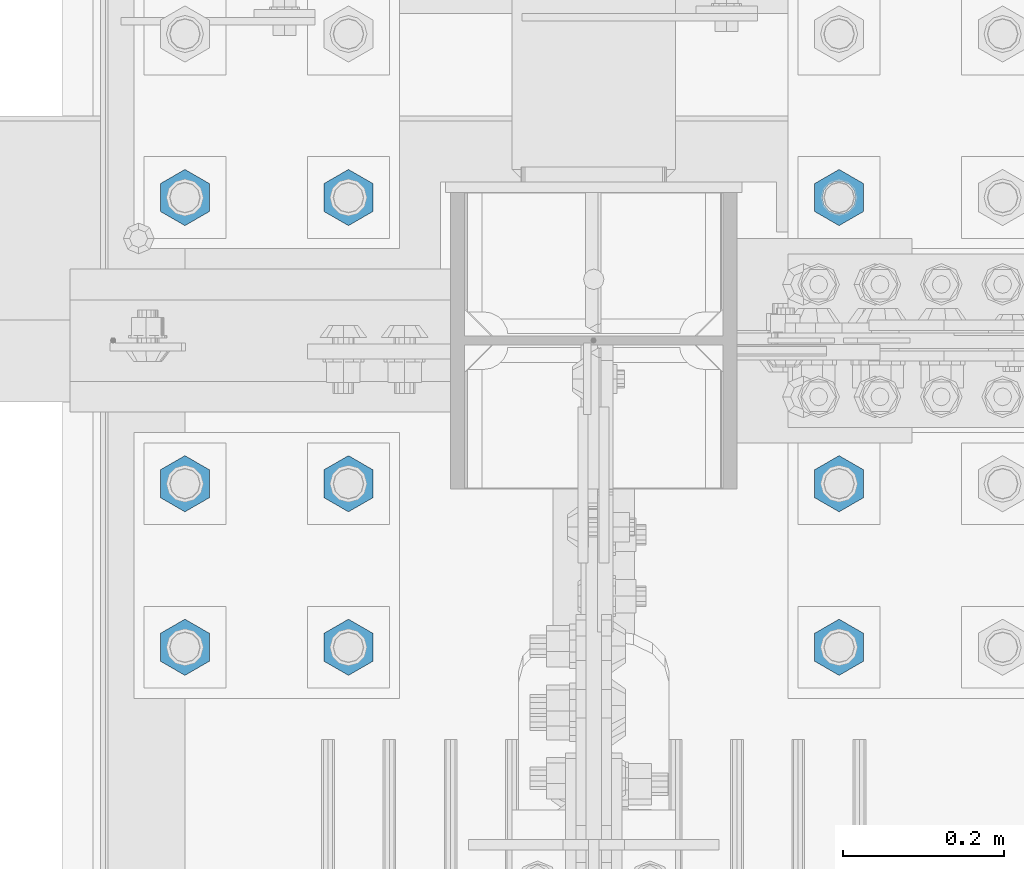
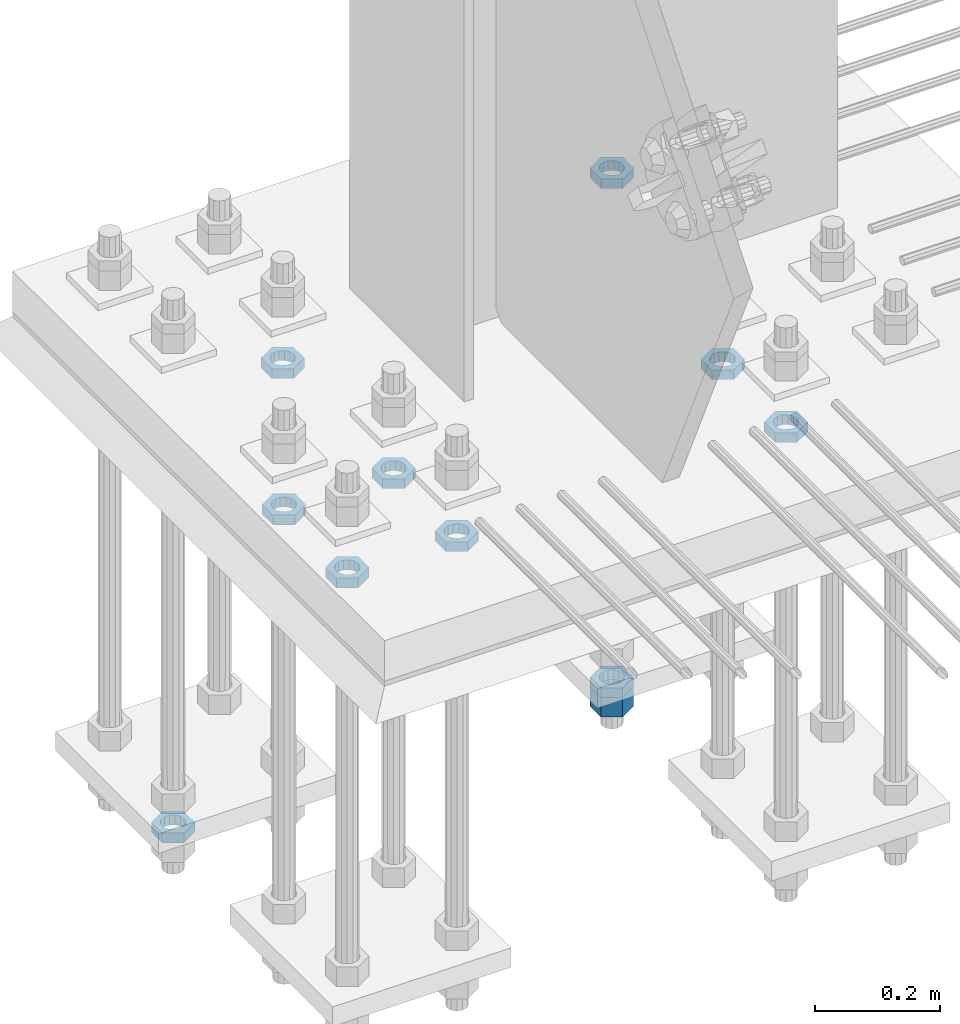
# One storey, part 2928 of 3843: 11 beams, 1 element without a shape of its own.
"""IFC2X3 building model written with IfcOpenShell, lengths in millimetres."""

from ifc_helpers import new_model, si_unit, frame, origin_with_axes, place, context, subcontext, project, spatial, faceted_brep, material, type_object, element, aggregate, save


model = new_model("IFC2X3")

# Units and contexts
model_context = context("Model", 3, precision=1e-05, world=origin_with_axes())
body_context = subcontext(model_context, "Body", "Model", "MODEL_VIEW")
ifc_project = project(units=[si_unit("LENGTHUNIT", "METRE", prefix="MILLI"), si_unit("AREAUNIT", "SQUARE_METRE"), si_unit("VOLUMEUNIT", "CUBIC_METRE"), si_unit("MASSUNIT", "GRAM", prefix="KILO"), si_unit("TIMEUNIT", "SECOND"), si_unit("PLANEANGLEUNIT", "RADIAN"), si_unit("SOLIDANGLEUNIT", "STERADIAN"), si_unit("THERMODYNAMICTEMPERATUREUNIT", "DEGREE_CELSIUS"), si_unit("LUMINOUSINTENSITYUNIT", "LUMEN")], contexts=[model_context])

# Site, building, storey
site_placement = place(None, origin_with_axes())
site = spatial("IfcSite", under=ifc_project, at=site_placement, CompositionType="ELEMENT")
building_placement = place(site_placement, origin_with_axes())
building = spatial("IfcBuilding", under=site, at=building_placement, Name="Undefined", CompositionType="ELEMENT")
storey_placement = place(building_placement, origin_with_axes())
storey = spatial("IfcBuildingStorey", under=building, at=storey_placement, Name="Undefined", CompositionType="ELEMENT", Elevation=0.0)

# Assembly, beams
assembly_placement = place(storey_placement, origin_with_axes())
assembly = element("IfcElementAssembly", 1, at=assembly_placement, inside=storey, Name="TEMPLATE", AssemblyPlace="NOTDEFINED", PredefinedType="RIGID_FRAME")
ifc_material = material(Name="STEEL/A572-50")
beam_type_1 = type_object("IfcBeamType", Name="1-1/2_HEAVY_HEX_NUT", PredefinedType="NOTDEFINED")
beam_1_placement = place(assembly_placement, frame((77317.6, 104736.9, 28746.4500015259), z_axis=(-1.0, 0.0, 0.0), x_axis=(0.0, 0.0, -1.0)))
beam_1 = element("IfcBeam", 2, at=beam_1_placement, type_object=beam_type_1, material=ifc_material, Name="NUT", ObjectType="1-1/2_HEAVY_HEX_NUT", context=body_context, shape_type="Brep", body=[
    faceted_brep([(0.0, -34.9199981689453, 0.0), (0.0, -17.4599990844727, -30.25), (38.0999999999985, -17.4599990844727, -30.25), (38.0999999999985, -34.9199981689453, 0.0), (0.0, 17.4599990844727, -30.25), (38.0999999999985, 17.4599990844727, -30.25), (0.0, 34.9199981689453, 0.0), (38.0999999999985, 34.9199981689453, 0.0), (0.0, 17.4599990844727, 30.25), (38.0999999999985, 17.4599990844727, 30.25), (0.0, -17.4599990844727, 30.25), (38.0999999999985, -17.4599990844727, 30.25), (0.0, 0.0, 20.6399993896484), (0.0, 8.9553601105581, 18.5959968835959), (38.0999999999985, 8.9553601105581, 18.5959968835959), (38.0999999999985, 0.0, 20.6399993896484), (0.0, 16.1370013209525, 12.8688291298167), (38.0999999999985, 16.1370013209525, 12.8688291298167), (0.0, 20.1225115123816, 4.59283194104501), (38.0999999999985, 20.1225115123816, 4.59283194104501), (0.0, 20.1225115123816, -4.59283194104501), (38.0999999999985, 20.1225115123816, -4.59283194104501), (0.0, 16.1370013209525, -12.8688291298167), (38.0999999999985, 16.1370013209525, -12.8688291298167), (0.0, 8.9553601105581, -18.5959968835959), (38.0999999999985, 8.9553601105581, -18.5959968835959), (0.0, 0.0, -20.6399993896484), (38.0999999999985, 0.0, -20.6399993896484), (0.0, -8.9553601105581, -18.5959968835959), (38.0999999999985, -8.9553601105581, -18.5959968835959), (0.0, -16.1370013209525, -12.8688291298167), (38.0999999999985, -16.1370013209525, -12.8688291298167), (0.0, -20.1225115123816, -4.59283194104501), (38.0999999999985, -20.1225115123816, -4.59283194104501), (0.0, -20.1225115123816, 4.59283194104501), (38.0999999999985, -20.1225115123816, 4.59283194104501), (0.0, -16.1370013209525, 12.8688291298167), (38.0999999999985, -16.1370013209525, 12.8688291298167), (0.0, -8.9553601105581, 18.5959968835959), (38.0999999999985, -8.9553601105581, 18.5959968835959)], [[[0, 1, 2, 3]], [[1, 4, 5, 2]], [[4, 6, 7, 5]], [[6, 8, 9, 7]], [[8, 10, 11, 9]], [[10, 0, 3, 11]], [[12, 13, 14, 15]], [[13, 16, 17, 14]], [[16, 18, 19, 17]], [[18, 20, 21, 19]], [[20, 22, 23, 21]], [[22, 24, 25, 23]], [[24, 26, 27, 25]], [[26, 28, 29, 27]], [[28, 30, 31, 29]], [[30, 32, 33, 31]], [[32, 34, 35, 33]], [[34, 36, 37, 35]], [[36, 38, 39, 37]], [[38, 12, 15, 39]], [[5, 7, 9, 11, 3, 2], [17, 19, 21, 23, 25, 27, 29, 31, 33, 35, 37, 39, 15, 14]], [[10, 8, 6, 4, 1, 0], [38, 36, 34, 32, 30, 28, 26, 24, 22, 20, 18, 16, 13, 12]]]),
])
beam_type_2 = type_object("IfcBeamType", Name="1-1/2_HALF_NUT", PredefinedType="NOTDEFINED")
beam_2_placement = place(assembly_placement, frame((76708.0, 104736.9, 29603.7), z_axis=(-1.0, 0.0, 0.0), x_axis=(0.0, 0.0, -1.0)))
beam_2 = element("IfcBeam", 3, at=beam_2_placement, type_object=beam_type_2, material=ifc_material, Name="NUT", ObjectType="1-1/2_HALF_NUT", context=body_context, shape_type="Brep", body=[
    faceted_brep([(0.0, -34.9199981689453, 0.0), (0.0, -17.4599990844727, -30.25), (19.0500000000029, -17.4599990844727, -30.25), (19.0500000000029, -34.9199981689453, 0.0), (0.0, 17.4599990844727, -30.25), (19.0500000000029, 17.4599990844727, -30.25), (0.0, 34.9199981689453, 0.0), (19.0500000000029, 34.9199981689453, 0.0), (0.0, 17.4599990844727, 30.25), (19.0500000000029, 17.4599990844727, 30.25), (0.0, -17.4599990844727, 30.25), (19.0500000000029, -17.4599990844727, 30.25), (0.0, 0.0, 20.6399993896484), (0.0, 8.9553601105581, 18.5959968835959), (19.0500000000029, 8.95536011056538, 18.5959968835959), (19.0500000000029, 0.0, 20.6399993896484), (0.0, 16.1370013209525, 12.8688291298167), (19.0500000000029, 16.1370013209489, 12.8688291298167), (0.0, 20.1225115123816, 4.59283194104501), (19.0500000000029, 20.1225115123852, 4.59283194104501), (0.0, 20.1225115123816, -4.59283194104501), (19.0500000000029, 20.1225115123852, -4.59283194104501), (0.0, 16.1370013209525, -12.8688291298167), (19.0500000000029, 16.1370013209489, -12.8688291298167), (0.0, 8.9553601105581, -18.5959968835959), (19.0500000000029, 8.95536011056538, -18.5959968835959), (0.0, 0.0, -20.6399993896484), (19.0500000000029, 0.0, -20.6399993896484), (0.0, -8.9553601105581, -18.5959968835959), (19.0500000000029, -8.95536011056538, -18.5959968835959), (0.0, -16.1370013209525, -12.8688291298167), (19.0500000000029, -16.1370013209489, -12.8688291298167), (0.0, -20.1225115123816, -4.59283194104501), (19.0500000000029, -20.1225115123852, -4.59283194104501), (0.0, -20.1225115123816, 4.59283194104501), (19.0500000000029, -20.1225115123852, 4.59283194104501), (0.0, -16.1370013209525, 12.8688291298167), (19.0500000000029, -16.1370013209489, 12.8688291298167), (0.0, -8.9553601105581, 18.5959968835959), (19.0500000000029, -8.95536011056538, 18.5959968835959)], [[[0, 1, 2, 3]], [[1, 4, 5, 2]], [[4, 6, 7, 5]], [[6, 8, 9, 7]], [[8, 10, 11, 9]], [[10, 0, 3, 11]], [[12, 13, 14, 15]], [[13, 16, 17, 14]], [[16, 18, 19, 17]], [[18, 20, 21, 19]], [[20, 22, 23, 21]], [[22, 24, 25, 23]], [[24, 26, 27, 25]], [[26, 28, 29, 27]], [[28, 30, 31, 29]], [[30, 32, 33, 31]], [[32, 34, 35, 33]], [[34, 36, 37, 35]], [[36, 38, 39, 37]], [[38, 12, 15, 39]], [[5, 7, 9, 11, 3, 2], [17, 19, 21, 23, 25, 27, 29, 31, 33, 35, 37, 39, 15, 14]], [[10, 8, 6, 4, 1, 0], [38, 36, 34, 32, 30, 28, 26, 24, 22, 20, 18, 16, 13, 12]]]),
])
beam_3_placement = place(assembly_placement, frame((76504.8, 104381.3, 29603.7), z_axis=(1.0, 0.0, 0.0), x_axis=(0.0, 0.0, -1.0)))
beam_3 = element("IfcBeam", 4, at=beam_3_placement, type_object=beam_type_2, material=ifc_material, Name="NUT", ObjectType="1-1/2_HALF_NUT", context=body_context, shape_type="Brep", body=[
    faceted_brep([(0.0, -34.9199981689453, 0.0), (0.0, -17.4599990844727, -30.25), (19.0500000000029, -17.4599990844727, -30.25), (19.0500000000029, -34.9199981689453, 0.0), (0.0, 17.4599990844727, -30.25), (19.0500000000029, 17.4599990844727, -30.25), (0.0, 34.9199981689453, 0.0), (19.0500000000029, 34.9199981689453, 0.0), (0.0, 17.4599990844727, 30.25), (19.0500000000029, 17.4599990844727, 30.25), (0.0, -17.4599990844727, 30.25), (19.0500000000029, -17.4599990844727, 30.25), (0.0, 0.0, 20.6399993896484), (0.0, 8.9553601105581, 18.5959968835959), (19.0500000000029, 8.95536011056538, 18.5959968835959), (19.0500000000029, 0.0, 20.6399993896484), (0.0, 16.1370013209525, 12.8688291298167), (19.0500000000029, 16.1370013209489, 12.8688291298167), (0.0, 20.1225115123816, 4.59283194104501), (19.0500000000029, 20.1225115123852, 4.59283194104501), (0.0, 20.1225115123816, -4.59283194104501), (19.0500000000029, 20.1225115123852, -4.59283194104501), (0.0, 16.1370013209525, -12.8688291298167), (19.0500000000029, 16.1370013209489, -12.8688291298167), (0.0, 8.9553601105581, -18.5959968835959), (19.0500000000029, 8.95536011056538, -18.5959968835959), (0.0, 0.0, -20.6399993896484), (19.0500000000029, 0.0, -20.6399993896484), (0.0, -8.9553601105581, -18.5959968835959), (19.0500000000029, -8.95536011056538, -18.5959968835959), (0.0, -16.1370013209525, -12.8688291298167), (19.0500000000029, -16.1370013209489, -12.8688291298167), (0.0, -20.1225115123816, -4.59283194104501), (19.0500000000029, -20.1225115123852, -4.59283194104501), (0.0, -20.1225115123816, 4.59283194104501), (19.0500000000029, -20.1225115123852, 4.59283194104501), (0.0, -16.1370013209525, 12.8688291298167), (19.0500000000029, -16.1370013209489, 12.8688291298167), (0.0, -8.9553601105581, 18.5959968835959), (19.0500000000029, -8.95536011056538, 18.5959968835959)], [[[0, 1, 2, 3]], [[1, 4, 5, 2]], [[4, 6, 7, 5]], [[6, 8, 9, 7]], [[8, 10, 11, 9]], [[10, 0, 3, 11]], [[12, 13, 14, 15]], [[13, 16, 17, 14]], [[16, 18, 19, 17]], [[18, 20, 21, 19]], [[20, 22, 23, 21]], [[22, 24, 25, 23]], [[24, 26, 27, 25]], [[26, 28, 29, 27]], [[28, 30, 31, 29]], [[30, 32, 33, 31]], [[32, 34, 35, 33]], [[34, 36, 37, 35]], [[36, 38, 39, 37]], [[38, 12, 15, 39]], [[5, 7, 9, 11, 3, 2], [17, 19, 21, 23, 25, 27, 29, 31, 33, 35, 37, 39, 15, 14]], [[10, 8, 6, 4, 1, 0], [38, 36, 34, 32, 30, 28, 26, 24, 22, 20, 18, 16, 13, 12]]]),
])
beam_4_placement = place(assembly_placement, frame((76504.8, 104178.1, 29603.7), z_axis=(1.0, 0.0, 0.0), x_axis=(0.0, 0.0, -1.0)))
beam_4 = element("IfcBeam", 5, at=beam_4_placement, type_object=beam_type_2, material=ifc_material, Name="NUT", ObjectType="1-1/2_HALF_NUT", context=body_context, shape_type="Brep", body=[
    faceted_brep([(0.0, -34.9199981689453, 0.0), (0.0, -17.4599990844727, -30.25), (19.0500000000029, -17.4599990844727, -30.25), (19.0500000000029, -34.9199981689453, 0.0), (0.0, 17.4599990844727, -30.25), (19.0500000000029, 17.4599990844727, -30.25), (0.0, 34.9199981689453, 0.0), (19.0500000000029, 34.9199981689453, 0.0), (0.0, 17.4599990844727, 30.25), (19.0500000000029, 17.4599990844727, 30.25), (0.0, -17.4599990844727, 30.25), (19.0500000000029, -17.4599990844727, 30.25), (0.0, 0.0, 20.6399993896484), (0.0, 8.9553601105581, 18.5959968835959), (19.0500000000029, 8.95536011056538, 18.5959968835959), (19.0500000000029, 0.0, 20.6399993896484), (0.0, 16.1370013209525, 12.8688291298167), (19.0500000000029, 16.1370013209489, 12.8688291298167), (0.0, 20.1225115123816, 4.59283194104501), (19.0500000000029, 20.1225115123852, 4.59283194104501), (0.0, 20.1225115123816, -4.59283194104501), (19.0500000000029, 20.1225115123852, -4.59283194104501), (0.0, 16.1370013209525, -12.8688291298167), (19.0500000000029, 16.1370013209489, -12.8688291298167), (0.0, 8.9553601105581, -18.5959968835959), (19.0500000000029, 8.95536011056538, -18.5959968835959), (0.0, 0.0, -20.6399993896484), (19.0500000000029, 0.0, -20.6399993896484), (0.0, -8.9553601105581, -18.5959968835959), (19.0500000000029, -8.95536011056538, -18.5959968835959), (0.0, -16.1370013209525, -12.8688291298167), (19.0500000000029, -16.1370013209489, -12.8688291298167), (0.0, -20.1225115123816, -4.59283194104501), (19.0500000000029, -20.1225115123852, -4.59283194104501), (0.0, -20.1225115123816, 4.59283194104501), (19.0500000000029, -20.1225115123852, 4.59283194104501), (0.0, -16.1370013209525, 12.8688291298167), (19.0500000000029, -16.1370013209489, 12.8688291298167), (0.0, -8.9553601105581, 18.5959968835959), (19.0500000000029, -8.95536011056538, 18.5959968835959)], [[[0, 1, 2, 3]], [[1, 4, 5, 2]], [[4, 6, 7, 5]], [[6, 8, 9, 7]], [[8, 10, 11, 9]], [[10, 0, 3, 11]], [[12, 13, 14, 15]], [[13, 16, 17, 14]], [[16, 18, 19, 17]], [[18, 20, 21, 19]], [[20, 22, 23, 21]], [[22, 24, 25, 23]], [[24, 26, 27, 25]], [[26, 28, 29, 27]], [[28, 30, 31, 29]], [[30, 32, 33, 31]], [[32, 34, 35, 33]], [[34, 36, 37, 35]], [[36, 38, 39, 37]], [[38, 12, 15, 39]], [[5, 7, 9, 11, 3, 2], [17, 19, 21, 23, 25, 27, 29, 31, 33, 35, 37, 39, 15, 14]], [[10, 8, 6, 4, 1, 0], [38, 36, 34, 32, 30, 28, 26, 24, 22, 20, 18, 16, 13, 12]]]),
])
beam_5_placement = place(assembly_placement, frame((76708.0, 104381.3, 29603.7), z_axis=(1.0, 0.0, 0.0), x_axis=(0.0, 0.0, -1.0)))
beam_5 = element("IfcBeam", 6, at=beam_5_placement, type_object=beam_type_2, material=ifc_material, Name="NUT", ObjectType="1-1/2_HALF_NUT", context=body_context, shape_type="Brep", body=[
    faceted_brep([(0.0, -34.9199981689453, 0.0), (0.0, -17.4599990844727, -30.25), (19.0500000000029, -17.4599990844727, -30.25), (19.0500000000029, -34.9199981689453, 0.0), (0.0, 17.4599990844727, -30.25), (19.0500000000029, 17.4599990844727, -30.25), (0.0, 34.9199981689453, 0.0), (19.0500000000029, 34.9199981689453, 0.0), (0.0, 17.4599990844727, 30.25), (19.0500000000029, 17.4599990844727, 30.25), (0.0, -17.4599990844727, 30.25), (19.0500000000029, -17.4599990844727, 30.25), (0.0, 0.0, 20.6399993896484), (0.0, 8.9553601105581, 18.5959968835959), (19.0500000000029, 8.95536011056538, 18.5959968835959), (19.0500000000029, 0.0, 20.6399993896484), (0.0, 16.1370013209525, 12.8688291298167), (19.0500000000029, 16.1370013209489, 12.8688291298167), (0.0, 20.1225115123816, 4.59283194104501), (19.0500000000029, 20.1225115123852, 4.59283194104501), (0.0, 20.1225115123816, -4.59283194104501), (19.0500000000029, 20.1225115123852, -4.59283194104501), (0.0, 16.1370013209525, -12.8688291298167), (19.0500000000029, 16.1370013209489, -12.8688291298167), (0.0, 8.9553601105581, -18.5959968835959), (19.0500000000029, 8.95536011056538, -18.5959968835959), (0.0, 0.0, -20.6399993896484), (19.0500000000029, 0.0, -20.6399993896484), (0.0, -8.9553601105581, -18.5959968835959), (19.0500000000029, -8.95536011056538, -18.5959968835959), (0.0, -16.1370013209525, -12.8688291298167), (19.0500000000029, -16.1370013209489, -12.8688291298167), (0.0, -20.1225115123816, -4.59283194104501), (19.0500000000029, -20.1225115123852, -4.59283194104501), (0.0, -20.1225115123816, 4.59283194104501), (19.0500000000029, -20.1225115123852, 4.59283194104501), (0.0, -16.1370013209525, 12.8688291298167), (19.0500000000029, -16.1370013209489, 12.8688291298167), (0.0, -8.9553601105581, 18.5959968835959), (19.0500000000029, -8.95536011056538, 18.5959968835959)], [[[0, 1, 2, 3]], [[1, 4, 5, 2]], [[4, 6, 7, 5]], [[6, 8, 9, 7]], [[8, 10, 11, 9]], [[10, 0, 3, 11]], [[12, 13, 14, 15]], [[13, 16, 17, 14]], [[16, 18, 19, 17]], [[18, 20, 21, 19]], [[20, 22, 23, 21]], [[22, 24, 25, 23]], [[24, 26, 27, 25]], [[26, 28, 29, 27]], [[28, 30, 31, 29]], [[30, 32, 33, 31]], [[32, 34, 35, 33]], [[34, 36, 37, 35]], [[36, 38, 39, 37]], [[38, 12, 15, 39]], [[5, 7, 9, 11, 3, 2], [17, 19, 21, 23, 25, 27, 29, 31, 33, 35, 37, 39, 15, 14]], [[10, 8, 6, 4, 1, 0], [38, 36, 34, 32, 30, 28, 26, 24, 22, 20, 18, 16, 13, 12]]]),
])
beam_6_placement = place(assembly_placement, frame((76708.0, 104178.1, 29603.7), z_axis=(1.0, 0.0, 0.0), x_axis=(0.0, 0.0, -1.0)))
beam_6 = element("IfcBeam", 7, at=beam_6_placement, type_object=beam_type_2, material=ifc_material, Name="NUT", ObjectType="1-1/2_HALF_NUT", context=body_context, shape_type="Brep", body=[
    faceted_brep([(0.0, -34.9199981689453, 0.0), (0.0, -17.4599990844727, -30.25), (19.0500000000029, -17.4599990844727, -30.25), (19.0500000000029, -34.9199981689453, 0.0), (0.0, 17.4599990844727, -30.25), (19.0500000000029, 17.4599990844727, -30.25), (0.0, 34.9199981689453, 0.0), (19.0500000000029, 34.9199981689453, 0.0), (0.0, 17.4599990844727, 30.25), (19.0500000000029, 17.4599990844727, 30.25), (0.0, -17.4599990844727, 30.25), (19.0500000000029, -17.4599990844727, 30.25), (0.0, 0.0, 20.6399993896484), (0.0, 8.9553601105581, 18.5959968835959), (19.0500000000029, 8.95536011056538, 18.5959968835959), (19.0500000000029, 0.0, 20.6399993896484), (0.0, 16.1370013209525, 12.8688291298167), (19.0500000000029, 16.1370013209489, 12.8688291298167), (0.0, 20.1225115123816, 4.59283194104501), (19.0500000000029, 20.1225115123852, 4.59283194104501), (0.0, 20.1225115123816, -4.59283194104501), (19.0500000000029, 20.1225115123852, -4.59283194104501), (0.0, 16.1370013209525, -12.8688291298167), (19.0500000000029, 16.1370013209489, -12.8688291298167), (0.0, 8.9553601105581, -18.5959968835959), (19.0500000000029, 8.95536011056538, -18.5959968835959), (0.0, 0.0, -20.6399993896484), (19.0500000000029, 0.0, -20.6399993896484), (0.0, -8.9553601105581, -18.5959968835959), (19.0500000000029, -8.95536011056538, -18.5959968835959), (0.0, -16.1370013209525, -12.8688291298167), (19.0500000000029, -16.1370013209489, -12.8688291298167), (0.0, -20.1225115123816, -4.59283194104501), (19.0500000000029, -20.1225115123852, -4.59283194104501), (0.0, -20.1225115123816, 4.59283194104501), (19.0500000000029, -20.1225115123852, 4.59283194104501), (0.0, -16.1370013209525, 12.8688291298167), (19.0500000000029, -16.1370013209489, 12.8688291298167), (0.0, -8.9553601105581, 18.5959968835959), (19.0500000000029, -8.95536011056538, 18.5959968835959)], [[[0, 1, 2, 3]], [[1, 4, 5, 2]], [[4, 6, 7, 5]], [[6, 8, 9, 7]], [[8, 10, 11, 9]], [[10, 0, 3, 11]], [[12, 13, 14, 15]], [[13, 16, 17, 14]], [[16, 18, 19, 17]], [[18, 20, 21, 19]], [[20, 22, 23, 21]], [[22, 24, 25, 23]], [[24, 26, 27, 25]], [[26, 28, 29, 27]], [[28, 30, 31, 29]], [[30, 32, 33, 31]], [[32, 34, 35, 33]], [[34, 36, 37, 35]], [[36, 38, 39, 37]], [[38, 12, 15, 39]], [[5, 7, 9, 11, 3, 2], [17, 19, 21, 23, 25, 27, 29, 31, 33, 35, 37, 39, 15, 14]], [[10, 8, 6, 4, 1, 0], [38, 36, 34, 32, 30, 28, 26, 24, 22, 20, 18, 16, 13, 12]]]),
])
beam_7_placement = place(assembly_placement, frame((77317.6, 104381.3, 29603.7), z_axis=(1.0, 0.0, 0.0), x_axis=(0.0, 0.0, -1.0)))
beam_7 = element("IfcBeam", 8, at=beam_7_placement, type_object=beam_type_2, material=ifc_material, Name="NUT", ObjectType="1-1/2_HALF_NUT", context=body_context, shape_type="Brep", body=[
    faceted_brep([(0.0, -34.9199981689453, 0.0), (0.0, -17.4599990844727, -30.25), (19.0500000000029, -17.4599990844727, -30.25), (19.0500000000029, -34.9199981689453, 0.0), (0.0, 17.4599990844727, -30.25), (19.0500000000029, 17.4599990844727, -30.25), (0.0, 34.9199981689453, 0.0), (19.0500000000029, 34.9199981689453, 0.0), (0.0, 17.4599990844727, 30.25), (19.0500000000029, 17.4599990844727, 30.25), (0.0, -17.4599990844727, 30.25), (19.0500000000029, -17.4599990844727, 30.25), (0.0, 0.0, 20.6399993896484), (0.0, 8.9553601105581, 18.5959968835959), (19.0500000000029, 8.95536011056538, 18.5959968835959), (19.0500000000029, 0.0, 20.6399993896484), (0.0, 16.1370013209525, 12.8688291298167), (19.0500000000029, 16.1370013209489, 12.8688291298167), (0.0, 20.1225115123816, 4.59283194104501), (19.0500000000029, 20.1225115123852, 4.59283194104501), (0.0, 20.1225115123816, -4.59283194104501), (19.0500000000029, 20.1225115123852, -4.59283194104501), (0.0, 16.1370013209525, -12.8688291298167), (19.0500000000029, 16.1370013209489, -12.8688291298167), (0.0, 8.9553601105581, -18.5959968835959), (19.0500000000029, 8.95536011056538, -18.5959968835959), (0.0, 0.0, -20.6399993896484), (19.0500000000029, 0.0, -20.6399993896484), (0.0, -8.9553601105581, -18.5959968835959), (19.0500000000029, -8.95536011056538, -18.5959968835959), (0.0, -16.1370013209525, -12.8688291298167), (19.0500000000029, -16.1370013209489, -12.8688291298167), (0.0, -20.1225115123816, -4.59283194104501), (19.0500000000029, -20.1225115123852, -4.59283194104501), (0.0, -20.1225115123816, 4.59283194104501), (19.0500000000029, -20.1225115123852, 4.59283194104501), (0.0, -16.1370013209525, 12.8688291298167), (19.0500000000029, -16.1370013209489, 12.8688291298167), (0.0, -8.9553601105581, 18.5959968835959), (19.0500000000029, -8.95536011056538, 18.5959968835959)], [[[0, 1, 2, 3]], [[1, 4, 5, 2]], [[4, 6, 7, 5]], [[6, 8, 9, 7]], [[8, 10, 11, 9]], [[10, 0, 3, 11]], [[12, 13, 14, 15]], [[13, 16, 17, 14]], [[16, 18, 19, 17]], [[18, 20, 21, 19]], [[20, 22, 23, 21]], [[22, 24, 25, 23]], [[24, 26, 27, 25]], [[26, 28, 29, 27]], [[28, 30, 31, 29]], [[30, 32, 33, 31]], [[32, 34, 35, 33]], [[34, 36, 37, 35]], [[36, 38, 39, 37]], [[38, 12, 15, 39]], [[5, 7, 9, 11, 3, 2], [17, 19, 21, 23, 25, 27, 29, 31, 33, 35, 37, 39, 15, 14]], [[10, 8, 6, 4, 1, 0], [38, 36, 34, 32, 30, 28, 26, 24, 22, 20, 18, 16, 13, 12]]]),
])
beam_8_placement = place(assembly_placement, frame((77317.6, 104178.1, 29603.7), z_axis=(1.0, 0.0, 0.0), x_axis=(0.0, 0.0, -1.0)))
beam_8 = element("IfcBeam", 9, at=beam_8_placement, type_object=beam_type_2, material=ifc_material, Name="NUT", ObjectType="1-1/2_HALF_NUT", context=body_context, shape_type="Brep", body=[
    faceted_brep([(0.0, -34.9199981689453, 0.0), (0.0, -17.4599990844727, -30.25), (19.0500000000029, -17.4599990844727, -30.25), (19.0500000000029, -34.9199981689453, 0.0), (0.0, 17.4599990844727, -30.25), (19.0500000000029, 17.4599990844727, -30.25), (0.0, 34.9199981689453, 0.0), (19.0500000000029, 34.9199981689453, 0.0), (0.0, 17.4599990844727, 30.25), (19.0500000000029, 17.4599990844727, 30.25), (0.0, -17.4599990844727, 30.25), (19.0500000000029, -17.4599990844727, 30.25), (0.0, 0.0, 20.6399993896484), (0.0, 8.9553601105581, 18.5959968835959), (19.0500000000029, 8.95536011056538, 18.5959968835959), (19.0500000000029, 0.0, 20.6399993896484), (0.0, 16.1370013209525, 12.8688291298167), (19.0500000000029, 16.1370013209489, 12.8688291298167), (0.0, 20.1225115123816, 4.59283194104501), (19.0500000000029, 20.1225115123852, 4.59283194104501), (0.0, 20.1225115123816, -4.59283194104501), (19.0500000000029, 20.1225115123852, -4.59283194104501), (0.0, 16.1370013209525, -12.8688291298167), (19.0500000000029, 16.1370013209489, -12.8688291298167), (0.0, 8.9553601105581, -18.5959968835959), (19.0500000000029, 8.95536011056538, -18.5959968835959), (0.0, 0.0, -20.6399993896484), (19.0500000000029, 0.0, -20.6399993896484), (0.0, -8.9553601105581, -18.5959968835959), (19.0500000000029, -8.95536011056538, -18.5959968835959), (0.0, -16.1370013209525, -12.8688291298167), (19.0500000000029, -16.1370013209489, -12.8688291298167), (0.0, -20.1225115123816, -4.59283194104501), (19.0500000000029, -20.1225115123852, -4.59283194104501), (0.0, -20.1225115123816, 4.59283194104501), (19.0500000000029, -20.1225115123852, 4.59283194104501), (0.0, -16.1370013209525, 12.8688291298167), (19.0500000000029, -16.1370013209489, 12.8688291298167), (0.0, -8.9553601105581, 18.5959968835959), (19.0500000000029, -8.95536011056538, 18.5959968835959)], [[[0, 1, 2, 3]], [[1, 4, 5, 2]], [[4, 6, 7, 5]], [[6, 8, 9, 7]], [[8, 10, 11, 9]], [[10, 0, 3, 11]], [[12, 13, 14, 15]], [[13, 16, 17, 14]], [[16, 18, 19, 17]], [[18, 20, 21, 19]], [[20, 22, 23, 21]], [[22, 24, 25, 23]], [[24, 26, 27, 25]], [[26, 28, 29, 27]], [[28, 30, 31, 29]], [[30, 32, 33, 31]], [[32, 34, 35, 33]], [[34, 36, 37, 35]], [[36, 38, 39, 37]], [[38, 12, 15, 39]], [[5, 7, 9, 11, 3, 2], [17, 19, 21, 23, 25, 27, 29, 31, 33, 35, 37, 39, 15, 14]], [[10, 8, 6, 4, 1, 0], [38, 36, 34, 32, 30, 28, 26, 24, 22, 20, 18, 16, 13, 12]]]),
])
beam_9_placement = place(assembly_placement, frame((77317.6, 104736.9, 28765.5), z_axis=(-1.0, 0.0, 0.0), x_axis=(0.0, 0.0, -1.0)))
beam_9 = element("IfcBeam", 10, at=beam_9_placement, type_object=beam_type_2, material=ifc_material, Name="NUT", ObjectType="1-1/2_HALF_NUT", context=body_context, shape_type="Brep", body=[
    faceted_brep([(0.0, -34.9199981689453, 0.0), (0.0, -17.4599990844727, -30.25), (19.0500000000029, -17.4599990844727, -30.25), (19.0500000000029, -34.9199981689453, 0.0), (0.0, 17.4599990844727, -30.25), (19.0500000000029, 17.4599990844727, -30.25), (0.0, 34.9199981689453, 0.0), (19.0500000000029, 34.9199981689453, 0.0), (0.0, 17.4599990844727, 30.25), (19.0500000000029, 17.4599990844727, 30.25), (0.0, -17.4599990844727, 30.25), (19.0500000000029, -17.4599990844727, 30.25), (0.0, 0.0, 20.6399993896484), (0.0, 8.9553601105581, 18.5959968835959), (19.0500000000029, 8.95536011056538, 18.5959968835959), (19.0500000000029, 0.0, 20.6399993896484), (0.0, 16.1370013209525, 12.8688291298167), (19.0500000000029, 16.1370013209489, 12.8688291298167), (0.0, 20.1225115123816, 4.59283194104501), (19.0500000000029, 20.1225115123852, 4.59283194104501), (0.0, 20.1225115123816, -4.59283194104501), (19.0500000000029, 20.1225115123852, -4.59283194104501), (0.0, 16.1370013209525, -12.8688291298167), (19.0500000000029, 16.1370013209489, -12.8688291298167), (0.0, 8.9553601105581, -18.5959968835959), (19.0500000000029, 8.95536011056538, -18.5959968835959), (0.0, 0.0, -20.6399993896484), (19.0500000000029, 0.0, -20.6399993896484), (0.0, -8.9553601105581, -18.5959968835959), (19.0500000000029, -8.95536011056538, -18.5959968835959), (0.0, -16.1370013209525, -12.8688291298167), (19.0500000000029, -16.1370013209489, -12.8688291298167), (0.0, -20.1225115123816, -4.59283194104501), (19.0500000000029, -20.1225115123852, -4.59283194104501), (0.0, -20.1225115123816, 4.59283194104501), (19.0500000000029, -20.1225115123852, 4.59283194104501), (0.0, -16.1370013209525, 12.8688291298167), (19.0500000000029, -16.1370013209489, 12.8688291298167), (0.0, -8.9553601105581, 18.5959968835959), (19.0500000000029, -8.95536011056538, 18.5959968835959)], [[[0, 1, 2, 3]], [[1, 4, 5, 2]], [[4, 6, 7, 5]], [[6, 8, 9, 7]], [[8, 10, 11, 9]], [[10, 0, 3, 11]], [[12, 13, 14, 15]], [[13, 16, 17, 14]], [[16, 18, 19, 17]], [[18, 20, 21, 19]], [[20, 22, 23, 21]], [[22, 24, 25, 23]], [[24, 26, 27, 25]], [[26, 28, 29, 27]], [[28, 30, 31, 29]], [[30, 32, 33, 31]], [[32, 34, 35, 33]], [[34, 36, 37, 35]], [[36, 38, 39, 37]], [[38, 12, 15, 39]], [[5, 7, 9, 11, 3, 2], [17, 19, 21, 23, 25, 27, 29, 31, 33, 35, 37, 39, 15, 14]], [[10, 8, 6, 4, 1, 0], [38, 36, 34, 32, 30, 28, 26, 24, 22, 20, 18, 16, 13, 12]]]),
])
beam_10_placement = place(assembly_placement, frame((77317.6, 104736.9, 29762.45), z_axis=(-1.0, 0.0, 0.0), x_axis=(0.0, 0.0, -1.0)))
beam_10 = element("IfcBeam", 11, at=beam_10_placement, type_object=beam_type_2, material=ifc_material, Name="NUT", ObjectType="1-1/2_HALF_NUT", context=body_context, shape_type="Brep", body=[
    faceted_brep([(0.0, -34.9199981689453, 0.0), (0.0, -17.4599990844727, -30.25), (19.0500000000029, -17.4599990844727, -30.25), (19.0500000000029, -34.9199981689453, 0.0), (0.0, 17.4599990844727, -30.25), (19.0500000000029, 17.4599990844727, -30.25), (0.0, 34.9199981689453, 0.0), (19.0500000000029, 34.9199981689453, 0.0), (0.0, 17.4599990844727, 30.25), (19.0500000000029, 17.4599990844727, 30.25), (0.0, -17.4599990844727, 30.25), (19.0500000000029, -17.4599990844727, 30.25), (0.0, 0.0, 20.6399993896484), (0.0, 8.9553601105581, 18.5959968835959), (19.0500000000029, 8.95536011056538, 18.5959968835959), (19.0500000000029, 0.0, 20.6399993896484), (0.0, 16.1370013209525, 12.8688291298167), (19.0500000000029, 16.1370013209489, 12.8688291298167), (0.0, 20.1225115123816, 4.59283194104501), (19.0500000000029, 20.1225115123852, 4.59283194104501), (0.0, 20.1225115123816, -4.59283194104501), (19.0500000000029, 20.1225115123852, -4.59283194104501), (0.0, 16.1370013209525, -12.8688291298167), (19.0500000000029, 16.1370013209489, -12.8688291298167), (0.0, 8.9553601105581, -18.5959968835959), (19.0500000000029, 8.95536011056538, -18.5959968835959), (0.0, 0.0, -20.6399993896484), (19.0500000000029, 0.0, -20.6399993896484), (0.0, -8.9553601105581, -18.5959968835959), (19.0500000000029, -8.95536011056538, -18.5959968835959), (0.0, -16.1370013209525, -12.8688291298167), (19.0500000000029, -16.1370013209489, -12.8688291298167), (0.0, -20.1225115123816, -4.59283194104501), (19.0500000000029, -20.1225115123852, -4.59283194104501), (0.0, -20.1225115123816, 4.59283194104501), (19.0500000000029, -20.1225115123852, 4.59283194104501), (0.0, -16.1370013209525, 12.8688291298167), (19.0500000000029, -16.1370013209489, 12.8688291298167), (0.0, -8.9553601105581, 18.5959968835959), (19.0500000000029, -8.95536011056538, 18.5959968835959)], [[[0, 1, 2, 3]], [[1, 4, 5, 2]], [[4, 6, 7, 5]], [[6, 8, 9, 7]], [[8, 10, 11, 9]], [[10, 0, 3, 11]], [[12, 13, 14, 15]], [[13, 16, 17, 14]], [[16, 18, 19, 17]], [[18, 20, 21, 19]], [[20, 22, 23, 21]], [[22, 24, 25, 23]], [[24, 26, 27, 25]], [[26, 28, 29, 27]], [[28, 30, 31, 29]], [[30, 32, 33, 31]], [[32, 34, 35, 33]], [[34, 36, 37, 35]], [[36, 38, 39, 37]], [[38, 12, 15, 39]], [[5, 7, 9, 11, 3, 2], [17, 19, 21, 23, 25, 27, 29, 31, 33, 35, 37, 39, 15, 14]], [[10, 8, 6, 4, 1, 0], [38, 36, 34, 32, 30, 28, 26, 24, 22, 20, 18, 16, 13, 12]]]),
])
beam_11_placement = place(assembly_placement, frame((76504.8, 104736.9, 28765.5), z_axis=(-1.0, 0.0, 0.0), x_axis=(0.0, 0.0, -1.0)))
beam_11 = element("IfcBeam", 12, at=beam_11_placement, type_object=beam_type_2, material=ifc_material, Name="NUT", ObjectType="1-1/2_HALF_NUT", context=body_context, shape_type="Brep", body=[
    faceted_brep([(0.0, -34.9199981689453, 0.0), (0.0, -17.4599990844727, -30.25), (19.0500000000029, -17.4599990844727, -30.25), (19.0500000000029, -34.9199981689453, 0.0), (0.0, 17.4599990844727, -30.25), (19.0500000000029, 17.4599990844727, -30.25), (0.0, 34.9199981689453, 0.0), (19.0500000000029, 34.9199981689453, 0.0), (0.0, 17.4599990844727, 30.25), (19.0500000000029, 17.4599990844727, 30.25), (0.0, -17.4599990844727, 30.25), (19.0500000000029, -17.4599990844727, 30.25), (0.0, 0.0, 20.6399993896484), (0.0, 8.9553601105581, 18.5959968835959), (19.0500000000029, 8.95536011056538, 18.5959968835959), (19.0500000000029, 0.0, 20.6399993896484), (0.0, 16.1370013209525, 12.8688291298167), (19.0500000000029, 16.1370013209489, 12.8688291298167), (0.0, 20.1225115123816, 4.59283194104501), (19.0500000000029, 20.1225115123852, 4.59283194104501), (0.0, 20.1225115123816, -4.59283194104501), (19.0500000000029, 20.1225115123852, -4.59283194104501), (0.0, 16.1370013209525, -12.8688291298167), (19.0500000000029, 16.1370013209489, -12.8688291298167), (0.0, 8.9553601105581, -18.5959968835959), (19.0500000000029, 8.95536011056538, -18.5959968835959), (0.0, 0.0, -20.6399993896484), (19.0500000000029, 0.0, -20.6399993896484), (0.0, -8.9553601105581, -18.5959968835959), (19.0500000000029, -8.95536011056538, -18.5959968835959), (0.0, -16.1370013209525, -12.8688291298167), (19.0500000000029, -16.1370013209489, -12.8688291298167), (0.0, -20.1225115123816, -4.59283194104501), (19.0500000000029, -20.1225115123852, -4.59283194104501), (0.0, -20.1225115123816, 4.59283194104501), (19.0500000000029, -20.1225115123852, 4.59283194104501), (0.0, -16.1370013209525, 12.8688291298167), (19.0500000000029, -16.1370013209489, 12.8688291298167), (0.0, -8.9553601105581, 18.5959968835959), (19.0500000000029, -8.95536011056538, 18.5959968835959)], [[[0, 1, 2, 3]], [[1, 4, 5, 2]], [[4, 6, 7, 5]], [[6, 8, 9, 7]], [[8, 10, 11, 9]], [[10, 0, 3, 11]], [[12, 13, 14, 15]], [[13, 16, 17, 14]], [[16, 18, 19, 17]], [[18, 20, 21, 19]], [[20, 22, 23, 21]], [[22, 24, 25, 23]], [[24, 26, 27, 25]], [[26, 28, 29, 27]], [[28, 30, 31, 29]], [[30, 32, 33, 31]], [[32, 34, 35, 33]], [[34, 36, 37, 35]], [[36, 38, 39, 37]], [[38, 12, 15, 39]], [[5, 7, 9, 11, 3, 2], [17, 19, 21, 23, 25, 27, 29, 31, 33, 35, 37, 39, 15, 14]], [[10, 8, 6, 4, 1, 0], [38, 36, 34, 32, 30, 28, 26, 24, 22, 20, 18, 16, 13, 12]]]),
])
aggregate(assembly, [beam_2, beam_3, beam_4, beam_5, beam_6, beam_7, beam_8, beam_9, beam_1, beam_10, beam_11])

save(model, "model.ifc")
